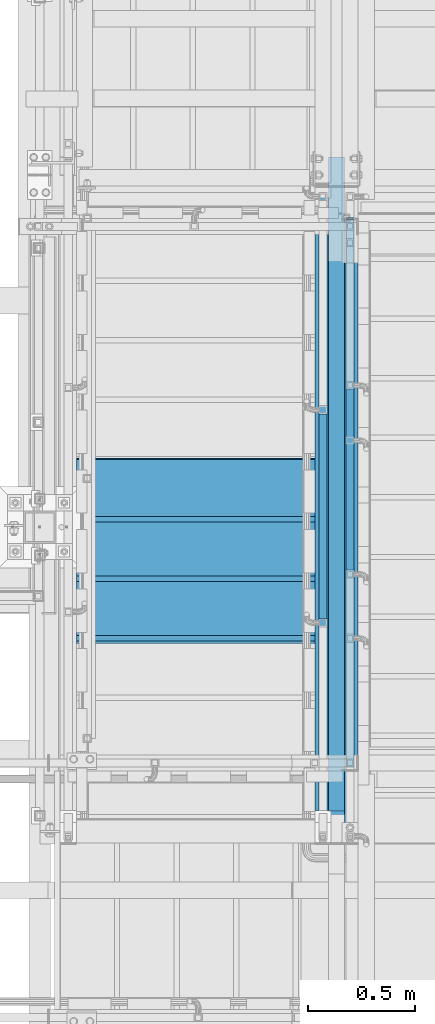
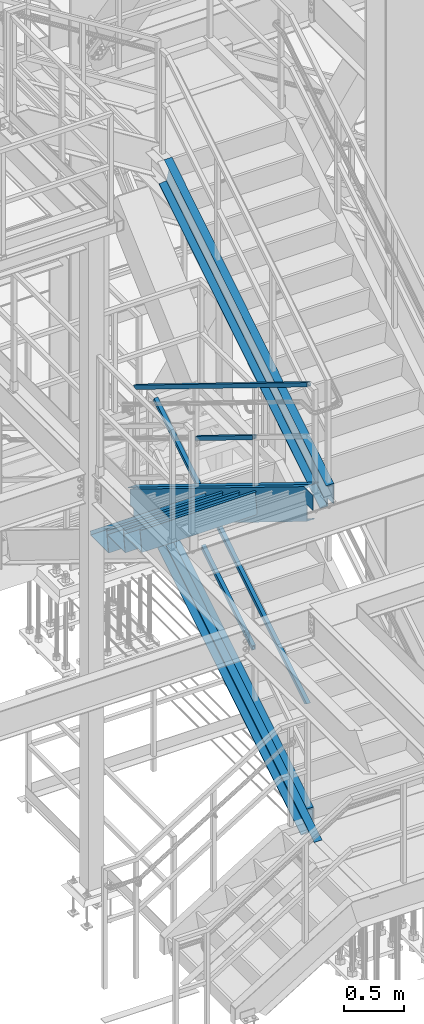
# One storey, part 1765 of 3843: 9 members, 3 beams, 7 elements without a shape of their own.
"""IFC2X3 building model written with IfcOpenShell, lengths in millimetres."""

from ifc_helpers import new_model, si_unit, frame, origin_with_axes, place, context, subcontext, project, spatial, faceted_brep, material, type_object, element, aggregate, save


model = new_model("IFC2X3")

# Units and contexts
model_context = context("Model", 3, precision=1e-05, world=origin_with_axes())
body_context = subcontext(model_context, "Body", "Model", "MODEL_VIEW")
ifc_project = project(units=[si_unit("LENGTHUNIT", "METRE", prefix="MILLI"), si_unit("AREAUNIT", "SQUARE_METRE"), si_unit("VOLUMEUNIT", "CUBIC_METRE"), si_unit("MASSUNIT", "GRAM", prefix="KILO"), si_unit("TIMEUNIT", "SECOND"), si_unit("PLANEANGLEUNIT", "RADIAN"), si_unit("SOLIDANGLEUNIT", "STERADIAN"), si_unit("THERMODYNAMICTEMPERATUREUNIT", "DEGREE_CELSIUS"), si_unit("LUMINOUSINTENSITYUNIT", "LUMEN")], contexts=[model_context])

# Site, building, storey
site_placement = place(None, origin_with_axes())
site = spatial("IfcSite", under=ifc_project, at=site_placement, CompositionType="ELEMENT")
building_placement = place(site_placement, origin_with_axes())
building = spatial("IfcBuilding", under=site, at=building_placement, Name="Undefined", CompositionType="ELEMENT")
storey_placement = place(building_placement, origin_with_axes())
storey = spatial("IfcBuildingStorey", under=building, at=storey_placement, Name="Undefined", CompositionType="ELEMENT", Elevation=0.0)

# Assembly, members
assembly_1_placement = place(storey_placement, origin_with_axes())
assembly_1 = element("IfcElementAssembly", 1, at=assembly_1_placement, inside=storey, Name="RAIL", AssemblyPlace="NOTDEFINED", PredefinedType="RIGID_FRAME")
ifc_material_1 = material()
member_type_1 = type_object("IfcMemberType", Name="HSS1-1/2X1-1/2X1/4", PredefinedType="NOTDEFINED")
member_1_placement = place(assembly_1_placement, frame((54317.8999999996, 20857.6333333278, 34316.70256118), z_axis=(0.0, 0.5240974250506, 0.851658317082227), x_axis=(0.0, -0.851658317082228, 0.524097425050598)))
member_1 = element("IfcMember", 2, at=member_1_placement, type_object=member_type_1, material=ifc_material_1, Name="RAIL", ObjectType="HSS1-1/2X1-1/2X1/4", context=body_context, shape_type="Brep", body=[
    faceted_brep([(10.6450480494532, -19.0499992350015, -19.0499992349796), (34.091200960931, -19.0499992350015, 19.0499992349942), (34.091200960931, 19.0499992350015, 19.0499992349942), (10.6450480494532, 19.0499992350015, -19.0499992349796), (30.1835087105574, 12.6999993300014, 12.6999993299978), (30.1835087105574, -12.6999993300014, 12.6999993299978), (14.5527402998268, -12.6999993300014, -12.6999993299833), (14.5527402998268, 12.6999993300014, -12.6999993299833), (1138.99270684942, 19.0499992350015, -19.049999237337), (1138.99270684942, -19.0499992350015, -19.049999237337), (1162.43885971598, -19.0499992350015, 19.0499992327605), (1162.43885971598, 19.0499992350015, 19.0499992327605), (1158.53116747309, -12.6999993299978, 12.6999993277495), (1158.53116747309, 12.6999993299978, 12.6999993277495), (1142.9003990923, 12.6999993299978, -12.6999993323188), (1142.9003990923, -12.6999993299978, -12.6999993323188)], [[[0, 1, 2, 3], [4, 5, 6, 7]], [[8, 9, 0, 3]], [[9, 10, 1, 0]], [[10, 11, 2, 1]], [[11, 8, 3, 2]], [[10, 9, 8, 11], [12, 13, 14, 15]], [[13, 12, 5, 4]], [[14, 13, 4, 7]], [[15, 14, 7, 6]], [[12, 15, 6, 5]]]),
])
member_2_placement = place(assembly_1_placement, frame((54317.8999999808, 18961.0999971442, 36017.1999969109), z_axis=(0.0, -0.5240974250506, -0.851658317082227), x_axis=(0.0, 0.851658317082228, -0.524097425050598)))
member_2 = element("IfcMember", 3, at=member_2_placement, type_object=member_type_1, material=ifc_material_1, Name="RAIL", ObjectType="HSS1-1/2X1-1/2X1/4", context=body_context, shape_type="Brep", body=[
    faceted_brep([(-3.59463567009516, 12.6999993300014, -12.6999993299978), (-3.59463567009516, -12.6999993300014, -12.6999993299978), (3407.051756529, -12.6999993299978, -12.6999993368299), (3407.051756529, 12.6999993299978, -12.6999993368299), (3.59463559381402, -12.6999993300014, 12.6999993299833), (3392.85835934866, -12.6999993299978, 12.6999993232967), (3.59463559381402, 12.6999993300014, 12.6999993299833), (3392.85835934866, 12.6999993299978, 12.6999993232967), (-5.39195355401171, 19.0499992350015, -19.0499992349942), (5.39195347770146, 19.0499992350015, 19.0499992349796), (3389.31000991947, 19.0499992350015, 19.0499992283221), (3410.60010595819, 19.0499992350015, -19.0499992418627), (5.39195347770146, -19.0499992350015, 19.0499992349796), (3389.31000991947, -19.0499992350015, 19.0499992283221), (-5.39195355401171, -19.0499992350015, -19.0499992349942), (3410.60010595819, -19.0499992350015, -19.0499992418627)], [[[0, 1, 2, 3]], [[1, 4, 5, 2]], [[4, 6, 7, 5]], [[6, 0, 3, 7]], [[8, 9, 10, 11]], [[9, 12, 13, 10]], [[12, 14, 15, 13]], [[14, 8, 11, 15]], [[13, 15, 11, 10], [5, 7, 3, 2]], [[14, 12, 9, 8], [6, 4, 1, 0]]]),
])
aggregate(assembly_1, [member_1, member_2])

assembly_2_placement = place(storey_placement, origin_with_axes())
assembly_2 = element("IfcElementAssembly", 4, at=assembly_2_placement, inside=storey, Name="RAIL", AssemblyPlace="NOTDEFINED", PredefinedType="RIGID_FRAME")
member_3_placement = place(assembly_2_placement, frame((54444.899999996, 20087.1666666675, 32566.0564098524), z_axis=(0.0, -0.524097425050603, 0.851658317082225), x_axis=(0.0, 0.851658317082228, 0.524097425050598)))
member_3 = element("IfcMember", 5, at=member_3_placement, type_object=member_type_1, material=ifc_material_1, Name="RAIL", ObjectType="HSS1-1/2X1-1/2X1/4", context=body_context, shape_type="Brep", body=[
    faceted_brep([(10.6450480494532, -19.0499992350015, -19.0499992349796), (34.091200960931, -19.0499992350015, 19.0499992349942), (34.091200960931, 19.0499992350015, 19.0499992349942), (10.6450480494532, 19.0499992350015, -19.0499992349796), (30.1835087105574, 12.6999993300014, 12.6999993299978), (30.1835087105574, -12.6999993300014, 12.6999993299978), (14.5527402998268, -12.6999993300014, -12.6999993299833), (14.5527402998268, 12.6999993300014, -12.6999993299833), (1004.7839546916, 19.0499992350015, -19.0499992338882), (1004.7839546916, -19.0499992350015, -19.0499992338882), (1028.23010755839, -19.0499992350015, 19.0499992361583), (1028.23010755839, 19.0499992350015, 19.0499992361583), (1024.32241531547, -12.6999993299978, 12.6999993311474), (1024.32241531547, 12.6999993299978, 12.6999993311474), (1008.69164693452, 12.6999993299978, -12.6999993288846), (1008.69164693452, -12.6999993299978, -12.6999993288846)], [[[0, 1, 2, 3], [4, 5, 6, 7]], [[8, 9, 0, 3]], [[9, 10, 1, 0]], [[10, 11, 2, 1]], [[11, 8, 3, 2]], [[10, 9, 8, 11], [12, 13, 14, 15]], [[13, 12, 5, 4]], [[14, 13, 4, 7]], [[15, 14, 7, 6]], [[12, 15, 6, 5]]]),
])
member_4_placement = place(assembly_2_placement, frame((54444.8999999914, 21755.1000004891, 34125.8769212941), z_axis=(0.0, 0.5240974250506, -0.851658317082227), x_axis=(0.0, -0.851658317082228, -0.524097425050598)))
member_4 = element("IfcMember", 6, at=member_4_placement, type_object=member_type_1, material=ifc_material_1, Name="RAIL", ObjectType="HSS1-1/2X1-1/2X1/4", context=body_context, shape_type="Brep", body=[
    faceted_brep([(-3.59463567009516, 12.6999993300014, -12.6999993299978), (-3.59463567009516, -12.6999993300014, -12.6999993299978), (3004.42549730713, -12.6999993299978, -12.6999993360187), (3004.42549730713, 12.6999993299978, -12.6999993360187), (3.59463559381402, -12.6999993300014, 12.6999993299833), (2990.23210012679, -12.6999993299978, 12.6999993241006), (3.59463559381402, 12.6999993300014, 12.6999993299833), (2990.23210012679, 12.6999993299978, 12.6999993241006), (-5.39195355401171, 19.0499992350015, -19.0499992349942), (5.39195347770146, 19.0499992350015, 19.0499992349796), (2986.6837506976, 19.0499992350015, 19.0499992291298), (3007.97384673633, 19.0499992350015, -19.0499992410514), (5.39195347770146, -19.0499992350015, 19.0499992349796), (2986.6837506976, -19.0499992350015, 19.0499992291298), (-5.39195355401171, -19.0499992350015, -19.0499992349942), (3007.97384673633, -19.0499992350015, -19.0499992410514)], [[[0, 1, 2, 3]], [[1, 4, 5, 2]], [[4, 6, 7, 5]], [[6, 0, 3, 7]], [[8, 9, 10, 11]], [[9, 12, 13, 10]], [[12, 14, 15, 13]], [[14, 8, 11, 15]], [[13, 15, 11, 10], [5, 7, 3, 2]], [[14, 12, 9, 8], [6, 4, 1, 0]]]),
])
aggregate(assembly_2, [member_3, member_4])

# Assembly, beams
assembly_3_placement = place(storey_placement, origin_with_axes())
assembly_3 = element("IfcElementAssembly", 7, at=assembly_3_placement, inside=storey, Name="STAIR", AssemblyPlace="NOTDEFINED", PredefinedType="RIGID_FRAME")
ifc_material_2 = material(Name="STEEL/ASTM A1011")
beam_type = type_object("IfcBeamType", PredefinedType="NOTDEFINED")
beam_1_placement = place(assembly_3_placement, frame((53721.0000001916, 19773.8999999726, 34432.9971126387), z_axis=(-1.0, 0.0, 0.0), x_axis=(0.0, 1.0, 0.0)))
beam_1 = element("IfcBeam", 8, at=beam_1_placement, type_object=beam_type, material=ifc_material_2, Name="TREAD", context=body_context, shape_type="Brep", body=[
    faceted_brep([(0.0, -1.58750000000146, -558.799999999999), (0.0, -1.58750000000146, 558.799999999999), (0.0, 1.58750000000146, 558.799999999999), (0.0, 1.58750000000146, -558.799999999999), (21.7215083258779, 1.58750000000146, 558.799999999999), (21.7215083258779, 1.58750000000146, -558.799999999999), (25.3999999999942, -1.58750000000146, -558.799999999999), (25.3999999999942, -1.58750000000146, 558.799999999999), (-11.1830371286633, 224.325961538467, 558.799999999999), (-11.1830371286633, 224.325961538467, -558.799999999999), (-7.50454545454704, 221.150961538464, -558.799999999999), (-7.50454545454704, 221.150961538464, 558.799999999999), (293.616962871325, 224.325961538467, 558.799999999999), (293.616962871325, 224.325961538467, -558.799999999999), (290.876539379024, 221.150961538464, -558.799999999999), (290.876539379024, 221.150961538464, 558.799999999999), (299.585432747743, 183.924011605752, 558.799999999999), (299.585432747743, 183.924011605752, -558.799999999999), (296.444520385252, 183.460013188564, 558.799999999999), (296.444520385252, 183.460013188564, -558.799999999999)], [[[0, 1, 2, 3]], [[3, 2, 4, 5]], [[1, 0, 6, 7]], [[5, 4, 8, 9]], [[7, 6, 10, 11]], [[9, 8, 12, 13]], [[11, 10, 14, 15]], [[13, 12, 16, 17]], [[12, 8, 4, 2, 1, 7, 11, 15, 18, 16]], [[15, 14, 19, 18]], [[14, 10, 6, 0, 3, 5, 9, 13, 17, 19]], [[18, 19, 17, 16]]]),
])
beam_2_placement = place(assembly_3_placement, frame((53721.0000001891, 20053.2999999755, 34261.0586512238), z_axis=(-1.0, 0.0, 0.0), x_axis=(0.0, 1.0, 0.0)))
beam_2 = element("IfcBeam", 9, at=beam_2_placement, type_object=beam_type, material=ifc_material_2, Name="TREAD", context=body_context, shape_type="Brep", body=[
    faceted_brep([(0.0, -1.58750000000146, -558.799999999999), (0.0, -1.58750000000146, 558.799999999999), (0.0, 1.58750000000146, 558.799999999999), (0.0, 1.58750000000146, -558.799999999999), (21.7215083258779, 1.58750000000146, 558.799999999999), (21.7215083258779, 1.58750000000146, -558.799999999999), (25.3999999999942, -1.58750000000146, -558.799999999999), (25.3999999999942, -1.58750000000146, 558.799999999999), (-11.1830371286633, 224.325961538467, 558.799999999999), (-11.1830371286633, 224.325961538467, -558.799999999999), (-7.50454545454704, 221.150961538464, -558.799999999999), (-7.50454545454704, 221.150961538464, 558.799999999999), (293.616962871325, 224.325961538467, 558.799999999999), (293.616962871325, 224.325961538467, -558.799999999999), (290.876539379024, 221.150961538464, -558.799999999999), (290.876539379024, 221.150961538464, 558.799999999999), (299.585432747743, 183.924011605752, 558.799999999999), (299.585432747743, 183.924011605752, -558.799999999999), (296.444520385252, 183.460013188564, 558.799999999999), (296.444520385252, 183.460013188564, -558.799999999999)], [[[0, 1, 2, 3]], [[3, 2, 4, 5]], [[1, 0, 6, 7]], [[5, 4, 8, 9]], [[7, 6, 10, 11]], [[9, 8, 12, 13]], [[11, 10, 14, 15]], [[13, 12, 16, 17]], [[12, 8, 4, 2, 1, 7, 11, 15, 18, 16]], [[15, 14, 19, 18]], [[14, 10, 6, 0, 3, 5, 9, 13, 17, 19]], [[18, 19, 17, 16]]]),
])
beam_3_placement = place(assembly_3_placement, frame((53721.0000001866, 20332.6999999785, 34089.1201898088), z_axis=(-1.0, 0.0, 0.0), x_axis=(0.0, 1.0, 0.0)))
beam_3 = element("IfcBeam", 10, at=beam_3_placement, type_object=beam_type, material=ifc_material_2, Name="TREAD", context=body_context, shape_type="Brep", body=[
    faceted_brep([(0.0, -1.58750000000146, -558.799999999999), (0.0, -1.58750000000146, 558.799999999999), (0.0, 1.58750000000146, 558.799999999999), (0.0, 1.58750000000146, -558.799999999999), (21.7215083258779, 1.58750000000146, 558.799999999999), (21.7215083258779, 1.58750000000146, -558.799999999999), (25.3999999999942, -1.58750000000146, -558.799999999999), (25.3999999999942, -1.58750000000146, 558.799999999999), (-11.1830371286633, 224.325961538467, 558.799999999999), (-11.1830371286633, 224.325961538467, -558.799999999999), (-7.50454545454704, 221.150961538464, -558.799999999999), (-7.50454545454704, 221.150961538464, 558.799999999999), (293.616962871325, 224.325961538467, 558.799999999999), (293.616962871325, 224.325961538467, -558.799999999999), (290.876539379024, 221.150961538464, -558.799999999999), (290.876539379024, 221.150961538464, 558.799999999999), (299.585432747743, 183.924011605752, 558.799999999999), (299.585432747743, 183.924011605752, -558.799999999999), (296.444520385252, 183.460013188564, 558.799999999999), (296.444520385252, 183.460013188564, -558.799999999999)], [[[0, 1, 2, 3]], [[3, 2, 4, 5]], [[1, 0, 6, 7]], [[5, 4, 8, 9]], [[7, 6, 10, 11]], [[9, 8, 12, 13]], [[11, 10, 14, 15]], [[13, 12, 16, 17]], [[12, 8, 4, 2, 1, 7, 11, 15, 18, 16]], [[15, 14, 19, 18]], [[14, 10, 6, 0, 3, 5, 9, 13, 17, 19]], [[18, 19, 17, 16]]]),
])

# Assembly, member
assembly_4_placement = place(storey_placement, origin_with_axes())
assembly_4 = element("IfcElementAssembly", 11, at=assembly_4_placement, inside=storey, Name="STAIR", AssemblyPlace="NOTDEFINED", PredefinedType="RIGID_FRAME")
ifc_material_3 = material(Name="STEEL/A36")
member_type_2 = type_object("IfcMemberType", Name="C12X20.7", PredefinedType="NOTDEFINED")
member_5_placement = place(assembly_4_placement, frame((54444.8999999684, 21625.3242642652, 36590.6543916032), z_axis=(0.0, -0.529536736899111, 0.848287005838379), x_axis=(0.0, -0.848287005838377, -0.529536736899114)))
member_5 = element("IfcMember", 12, at=member_5_placement, type_object=member_type_2, material=ifc_material_3, Name="STAIR", ObjectType="C12X20.7", context=body_context, shape_type="Brep", body=[
    faceted_brep([(3273.27383757877, -38.0999999999985, -152.399999989619), (3273.27383757877, 38.0999999999985, -152.399999989619), (3226.14861852725, 38.0999999999985, -76.9081442155075), (3226.14861852725, 30.1624999999985, -76.9081442155075), (3262.20909535318, 30.1624999999985, -134.674927489679), (3269.30831260967, -38.0999999999985, -146.047459989633), (3312.33457831451, 30.1624999999985, -23.1072117502554), (3312.33457831451, 38.0999999999985, -23.1072117502554), (0.0, -38.0999999999985, 152.400000000001), (1.82001331920401, -38.0999999999985, 146.047460000002), (3206.74105595912, -38.0999999999985, 146.047460009708), (3202.77553099003, -38.0999999999985, 152.400000009686), (0.0, 38.0999999999985, 152.400000000001), (3202.77553099003, 38.0999999999985, 152.400000009686), (87.3256158388394, -38.0999999999985, -152.400000000001), (85.5056045034071, -38.0999999999985, -146.047460000002), (82.2473585006228, 30.1624999999985, -134.674927499997), (5.0782593219883, 30.1624999999985, 134.674927499997), (87.3256158388394, 38.0999999999985, -152.400000000001), (3213.84027321559, 30.1624999999985, 134.674927509746)], [[[0, 1, 2, 3, 4, 5]], [[6, 3, 2, 7]], [[8, 9, 10, 11]], [[12, 8, 11, 13]], [[14, 15, 16, 17, 9, 8, 12, 18]], [[9, 17, 19, 10]], [[13, 11, 10, 19, 6, 7]], [[1, 18, 12, 13, 7, 2]], [[14, 18, 1, 0]], [[15, 14, 0, 5]], [[16, 15, 5, 4]], [[19, 17, 16, 4, 3, 6]]]),
])
aggregate(assembly_4, [member_5])

# Member
member_6_placement = place(assembly_3_placement, frame((54317.9000000347, 18888.4168240372, 34846.007269362), z_axis=(0.0, 0.5240974250506, 0.851658317082227), x_axis=(0.0, 0.851658317082228, -0.524097425050598)))
member_6 = element("IfcMember", 13, at=member_6_placement, type_object=member_type_2, material=ifc_material_3, Name="STAIR", ObjectType="C12X20.7", context=body_context, shape_type="Brep", body=[
    faceted_brep([(3564.1707039677, 38.0999999999985, -152.399999993482), (3564.1707039677, -38.0999999999985, -152.399999993482), (141.847523961862, -38.0999999999985, -152.400000000285), (141.847523961862, 38.0999999999985, -152.400000000285), (3560.26144858938, -38.0999999999985, -146.047459993461), (137.93826858355, -38.0999999999985, -146.047460000271), (-36.4909749530761, 30.1624999999985, -56.4570255565413), (-36.4909749530761, 38.0999999999985, -56.4570255565413), (50.0375100623132, 38.0999999999985, -3.20872717089514), (50.0375100623132, 30.1624999999985, -3.20872717089514), (130.939787056364, 30.1624999999985, -134.674927500237), (3553.2629670622, 30.1624999999985, -134.674927493434), (3476.96871832869, 38.0999999999985, -10.6967731013137), (3476.96871832869, 30.1624999999985, -10.6967731013137), (3525.64099115382, 30.1624999999985, 19.2553947430933), (3525.64099115382, 38.0999999999985, 19.2553947430861), (3443.7058495859, 38.0999999999985, 152.400000007416), (3443.7058495859, -38.0999999999985, 152.400000007416), (3447.61510496417, -38.0999999999985, 146.047460007401), (3454.61358649127, 30.1624999999985, 134.674927507374), (12.1160678339984, -38.0999999999985, 152.400000000598), (1.79319031737396, -38.0999999999985, 146.047460000555), (-16.6871750248829, 30.1624999999985, 134.674927500469), (-116.363420922205, 30.1624999999985, 73.3356993543057), (-116.363420922205, 38.0999999999985, 73.3356993543057), (12.1160678339984, 38.0999999999985, 152.400000000598)], [[[0, 1, 2, 3]], [[1, 4, 5, 2]], [[6, 7, 8, 9]], [[2, 5, 10, 9, 8, 3]], [[4, 11, 10, 5]], [[1, 0, 12, 13, 11, 4]], [[14, 13, 12, 15]], [[16, 17, 18, 19, 14, 15]], [[18, 17, 20, 21]], [[19, 18, 21, 22]], [[6, 9, 10, 11, 13, 14, 19, 22, 23]], [[7, 6, 23, 24]], [[16, 15, 12, 0, 3, 8, 7, 24, 25]], [[17, 16, 25, 20]], [[24, 23, 22, 21, 20, 25]]]),
])

aggregate(assembly_3, [beam_1, beam_2, beam_3, member_6])

# Assembly, member
assembly_5_placement = place(storey_placement, origin_with_axes())
assembly_5 = element("IfcElementAssembly", 14, at=assembly_5_placement, inside=storey, Name="STAIR", AssemblyPlace="NOTDEFINED", PredefinedType="RIGID_FRAME")
member_7_placement = place(assembly_5_placement, frame((54444.8999999809, 21827.7831760084, 32954.684193837), z_axis=(0.0, -0.524097425050603, 0.851658317082225), x_axis=(0.0, -0.851658317082228, -0.524097425050598)))
member_7 = element("IfcMember", 15, at=member_7_placement, type_object=member_type_2, material=ifc_material_3, Name="STAIR", ObjectType="C12X20.7", context=body_context, shape_type="Brep", body=[
    faceted_brep([(3096.07058361953, 30.1624999999985, 38.8075043960889), (3031.17421985778, 30.1624999999985, -1.12871939282195), (3031.17421985778, 38.0999999999985, -1.12871939282195), (3096.07058361953, 38.0999999999985, 38.8075043960889), (3124.2642385374, -38.0999999999985, -152.399999994352), (3124.2642385374, 38.0999999999985, -152.399999994352), (3113.35650163191, 30.1624999999985, -134.674927494303), (3120.35498315909, -38.0999999999985, -146.04745999433), (1.79803683332284, -38.0999999999985, 146.047459999862), (5.01694334564672, 30.1624999999985, 134.674927499867), (3037.07524641669, 30.1624999999985, 134.674927506549), (3030.07676488959, -38.0999999999985, 146.047460006579), (0.0, -38.0999999999985, 152.400000000001), (3026.16750951132, -38.0999999999985, 152.400000006597), (0.0, 38.0999999999985, 152.400000000001), (3026.16750951132, 38.0999999999985, 152.400000006597), (86.2712597135396, -38.0999999999985, -152.39999999988), (84.4732228755893, -38.0999999999985, -146.047459999883), (81.2543163632508, 30.1624999999985, -134.674927499889), (86.2712597135396, 38.0999999999985, -152.39999999988)], [[[0, 1, 2, 3]], [[4, 5, 2, 1, 6, 7]], [[8, 9, 10, 11]], [[12, 8, 11, 13]], [[14, 12, 13, 15]], [[16, 17, 18, 9, 8, 12, 14, 19]], [[17, 16, 4, 7]], [[18, 17, 7, 6]], [[0, 10, 9, 18, 6, 1]], [[15, 13, 11, 10, 0, 3]], [[19, 14, 15, 3, 2, 5]], [[16, 19, 5, 4]]]),
])
aggregate(assembly_5, [member_7])

assembly_6_placement = place(storey_placement, origin_with_axes())
assembly_6 = element("IfcElementAssembly", 16, at=assembly_6_placement, inside=storey, Name="ref.", AssemblyPlace="NOTDEFINED", PredefinedType="RIGID_FRAME")
ifc_material_4 = material(Name="STEEL/Steel_Undefined")
member_type_3 = type_object("IfcMemberType", PredefinedType="NOTDEFINED")
member_8_placement = place(assembly_6_placement, frame((54381.4, 22040.0252623057, 33081.7729061705), z_axis=(1.0, 0.0, 0.0), x_axis=(0.0, -0.851658317082228, 0.524097425050598)))
member_8 = element("IfcMember", 17, at=member_8_placement, type_object=member_type_3, material=ifc_material_4, Name="ref.", context=body_context, shape_type="Brep", body=[
    faceted_brep([(0.0, 3.17500000000291, -38.0999999999985), (0.0, 3.17500000000291, 38.0999999999985), (3596.60816004726, 3.17500000716245, 38.0999999999985), (3596.60816004726, 3.17500000716245, -38.0999999999985), (0.0, -3.17500000000291, 38.0999999999985), (3596.60816004727, -3.17499999285792, 38.0999999999985), (0.0, -3.17500000000291, -38.0999999999985), (3596.60816004727, -3.17499999285792, -38.0999999999985)], [[[0, 1, 2, 3]], [[1, 4, 5, 2]], [[4, 6, 7, 5]], [[6, 0, 3, 7]], [[5, 7, 3, 2]], [[6, 4, 1, 0]]]),
])
aggregate(assembly_6, [member_8])

assembly_7_placement = place(storey_placement, origin_with_axes())
assembly_7 = element("IfcElementAssembly", 18, at=assembly_7_placement, inside=storey, Name="ref.", AssemblyPlace="NOTDEFINED", PredefinedType="RIGID_FRAME")
member_9_placement = place(assembly_7_placement, frame((54381.4, 18914.2997355029, 31336.9882919403), z_axis=(-1.0, 0.0, 0.0), x_axis=(0.0, 0.851658317082228, 0.524097425050598)))
member_9 = element("IfcMember", 19, at=member_9_placement, type_object=member_type_3, material=ifc_material_4, Name="ref.", context=body_context, shape_type="Brep", body=[
    faceted_brep([(0.0, 3.17500000000291, -38.0999999999985), (0.0, 3.17500000000291, 38.0999999999985), (3329.12266048147, 3.17499999630309, 38.0999999999985), (3329.12266048147, 3.17499999630309, -38.0999999999985), (0.0, -3.17500000000291, 38.0999999999985), (3329.12266048146, -3.1750000036991, 38.0999999999985), (0.0, -3.17500000000291, -38.0999999999985), (3329.12266048146, -3.1750000036991, -38.0999999999985)], [[[0, 1, 2, 3]], [[1, 4, 5, 2]], [[4, 6, 7, 5]], [[6, 0, 3, 7]], [[5, 7, 3, 2]], [[6, 4, 1, 0]]]),
])
aggregate(assembly_7, [member_9])

save(model, "model.ifc")
